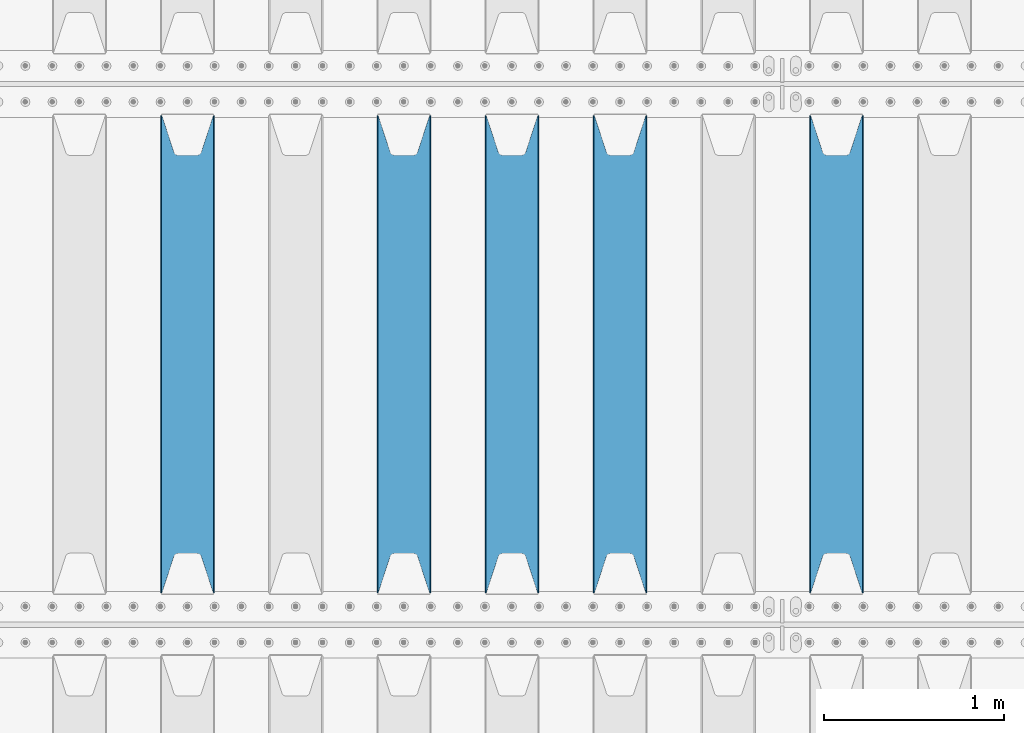
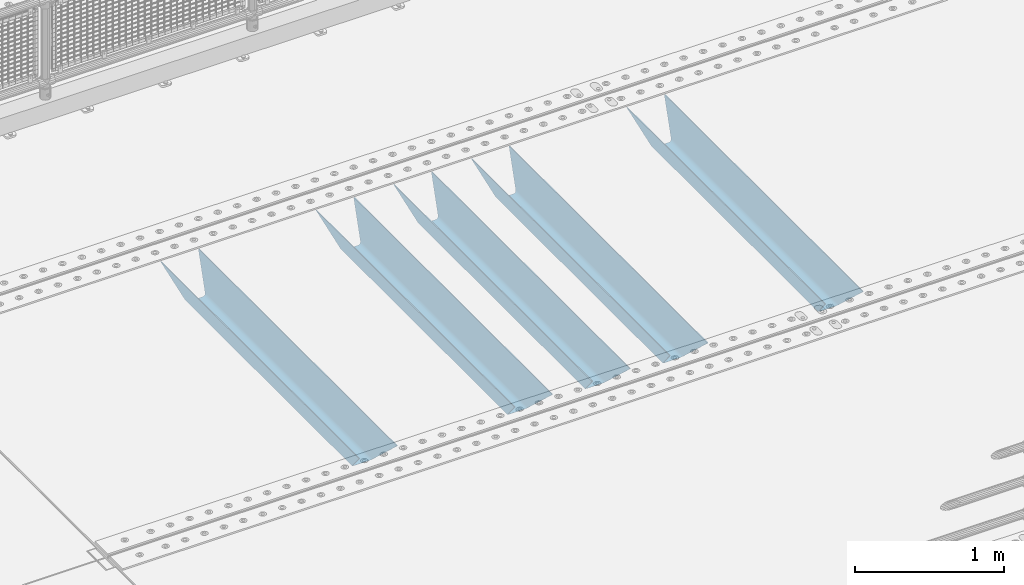
# One storey, part 111 of 247: 5 beams.
"""IFC2X3 building model written with IfcOpenShell, lengths in millimetres."""

from ifc_helpers import new_model, si_unit, frame, origin_with_axes, place, context, subcontext, project, spatial, faceted_brep, material, type_object, element, save


model = new_model("IFC2X3")

# Units and contexts
model_context = context("Model", 3, precision=1e-05, world=origin_with_axes())
body_context = subcontext(model_context, "Body", "Model", "MODEL_VIEW")
ifc_project = project(units=[si_unit("LENGTHUNIT", "METRE", prefix="MILLI"), si_unit("AREAUNIT", "SQUARE_METRE"), si_unit("VOLUMEUNIT", "CUBIC_METRE"), si_unit("MASSUNIT", "GRAM", prefix="KILO"), si_unit("TIMEUNIT", "SECOND"), si_unit("PLANEANGLEUNIT", "RADIAN"), si_unit("SOLIDANGLEUNIT", "STERADIAN"), si_unit("THERMODYNAMICTEMPERATUREUNIT", "DEGREE_CELSIUS"), si_unit("LUMINOUSINTENSITYUNIT", "LUMEN")], contexts=[model_context])

# Site, building, storey
site_placement = place(None, origin_with_axes())
site = spatial("IfcSite", under=ifc_project, at=site_placement, CompositionType="ELEMENT")
building_placement = place(site_placement, origin_with_axes())
building = spatial("IfcBuilding", under=site, at=building_placement, Name="Standard", CompositionType="ELEMENT")
storey_placement = place(building_placement, origin_with_axes())
storey = spatial("IfcBuildingStorey", under=building, at=storey_placement, Name="Undefined", CompositionType="ELEMENT", Elevation=0.0)

# Beams
ifc_material = material(Name="STEEL/S355N")
beam_type = type_object("IfcBeamType", PredefinedType="NOTDEFINED")
beam_1_placement = place(storey_placement, frame((5800.0, 3175.0, -115.0), z_axis=(0.0, 0.0, 1.0), x_axis=(0.0, 1.0, 0.0)))
element("IfcBeam", 1, at=beam_1_placement, inside=storey, type_object=beam_type, material=ifc_material, context=body_context, shape_type="Brep", body=[
    faceted_brep([(0.0, 150.0, 115.0), (0.0, 143.689999999999, 115.0), (2650.00000000297, 143.689999999999, 115.0), (2650.00000000297, 150.0, 115.0), (2650.00000000297, 142.059565218402, 110.0000000031), (2650.00000000297, 148.369565218403, 110.0000000031), (2441.90079219208, -80.1103600731112, -98.0992078077845), (2437.7588105432, -77.5672621345584, -102.241189456673), (2434.06523489746, -74.4080125315522, -105.934765102404), (2430.91086095089, -70.710272125576, -109.089139048974), (2428.37322971128, -66.5649389910068, -111.626770288588), (2426.51472138054, -62.0739139532889, -113.485278619323), (2425.38102192091, -57.3475956567672, -114.618978078955), (2424.99999999987, -52.5021667386536, -115.0), (2424.99999999987, 52.5021667386536, -115.0), (2425.38102192091, 57.3475956567672, -114.618978078955), (2426.51472138054, 62.0739139532889, -113.485278619323), (2428.37322971128, 66.5649389910068, -111.626770288588), (2430.91086095089, 70.710272125576, -109.089139048974), (2434.06523489746, 74.4080125315522, -105.934765102404), (2437.7588105432, 77.5672621345584, -102.241189456673), (2441.90079219208, 80.1103600731112, -98.0992078077846), (2446.38936140511, 81.9747917625791, -93.6106385947584), (2448.24948500409, 76.2713538057251, -91.7505149957729), (2444.62967112262, 74.76777986261, -95.3703288772456), (2441.28936334126, 72.7168944282894, -98.710636658607), (2438.31067330438, 70.1691124903846, -101.689326695487), (2435.76682334747, 67.1870637758839, -104.233176652398), (2433.72034654133, 63.8440531834895, -106.279653458539), (2432.22154950041, 60.222258798236, -107.778450499454), (2431.30727574265, 56.4107117849089, -108.692724257221), (2430.99999999987, 52.5031078186876, -109.0), (2430.99999999987, -52.5031078186876, -109.0), (2431.30727574265, -56.4107117849089, -108.692724257221), (2432.22154950041, -60.222258798236, -107.778450499454), (2433.72034654133, -63.8440531834895, -106.279653458539), (2435.76682334747, -67.1870637758839, -104.233176652398), (2438.31067330438, -70.1691124903846, -101.689326695487), (2441.28936334126, -72.7168944282894, -98.7106366586071), (2444.62967112262, -74.76777986261, -95.3703288772457), (2448.24948500409, -76.2713538057251, -91.7505149957729), (2650.00000000297, -142.059565218402, 110.0000000031), (2650.00000000297, -148.369565218403, 110.0000000031), (2446.38936140511, -81.9747917625791, -93.6106385947584), (2650.00000000297, -143.689999999999, 115.0), (2650.00000000297, -150.0, 115.0), (0.0, -143.689999999999, 115.0), (0.0, -150.0, 115.0), (0.0, -148.369565218261, 110.000000002663), (203.610638597422, -81.9747917625791, -93.6106385947584), (208.099207810448, -80.1103600731112, -98.0992078077845), (212.241189459336, -77.5672621345584, -102.241189456673), (215.934765105068, -74.4080125315522, -105.934765102404), (219.089139051637, -70.710272125576, -109.089139048974), (221.626770291251, -66.5649389910068, -111.626770288588), (223.485278621985, -62.0739139532889, -113.485278619323), (224.618978081617, -57.3475956567672, -114.618978078955), (225.000000002663, -52.5021667386536, -115.0), (225.000000002663, 52.5021667386536, -115.0), (224.618978081617, 57.3475956567672, -114.618978078955), (223.485278621985, 62.0739139532889, -113.485278619323), (221.626770291251, 66.5649389910068, -111.626770288588), (219.089139051637, 70.710272125576, -109.089139048974), (215.934765105068, 74.4080125315522, -105.934765102404), (212.241189459336, 77.5672621345584, -102.241189456673), (208.099207810448, 80.1103600731112, -98.0992078077846), (203.610638597422, 81.9747917625791, -93.6106385947584), (0.0, 148.369565218261, 110.000000002663), (0.0, 142.05956521826, 110.000000002663), (201.750514998436, 76.2713538057251, -91.7505149957729), (205.370328879908, 74.76777986261, -95.3703288772456), (208.710636661271, 72.7168944282894, -98.710636658607), (211.68932669815, 70.1691124903846, -101.689326695487), (214.233176655061, 67.1870637758839, -104.233176652398), (216.279653461202, 63.8440531834895, -106.279653458539), (217.778450502117, 60.222258798236, -107.778450499454), (218.692724259885, 56.4107117849089, -108.692724257221), (219.000000002663, 52.5031078186876, -109.0), (219.000000002663, -52.5031078186876, -109.0), (218.692724259885, -56.4107117849089, -108.692724257221), (217.778450502117, -60.222258798236, -107.778450499454), (216.279653461202, -63.8440531834895, -106.279653458539), (214.233176655061, -67.1870637758839, -104.233176652398), (211.68932669815, -70.1691124903846, -101.689326695487), (208.710636661271, -72.7168944282894, -98.7106366586071), (205.370328879908, -74.76777986261, -95.3703288772457), (201.750514998436, -76.2713538057251, -91.7505149957729), (0.0, -142.05956521826, 110.000000002663)], [[[0, 1, 2, 3]], [[3, 2, 4, 5]], [[6, 7, 8, 9, 10, 11, 12, 13, 14, 15, 16, 17, 18, 19, 20, 21, 22, 5, 4, 23, 24, 25, 26, 27, 28, 29, 30, 31, 32, 33, 34, 35, 36, 37, 38, 39, 40, 41, 42, 43]], [[44, 45, 42, 41]], [[46, 47, 45, 44]], [[43, 42, 45, 47, 48, 49]], [[6, 43, 49, 50]], [[7, 6, 50, 51]], [[8, 7, 51, 52]], [[9, 8, 52, 53]], [[10, 9, 53, 54]], [[11, 10, 54, 55]], [[12, 11, 55, 56]], [[13, 12, 56, 57]], [[14, 13, 57, 58]], [[15, 14, 58, 59]], [[16, 15, 59, 60]], [[17, 16, 60, 61]], [[18, 17, 61, 62]], [[19, 18, 62, 63]], [[20, 19, 63, 64]], [[21, 20, 64, 65]], [[22, 21, 65, 66]], [[0, 3, 5, 22, 66, 67]], [[1, 0, 67, 68]], [[23, 4, 2, 1, 68, 69]], [[24, 23, 69, 70]], [[25, 24, 70, 71]], [[26, 25, 71, 72]], [[27, 26, 72, 73]], [[28, 27, 73, 74]], [[29, 28, 74, 75]], [[30, 29, 75, 76]], [[31, 30, 76, 77]], [[32, 31, 77, 78]], [[33, 32, 78, 79]], [[34, 33, 79, 80]], [[35, 34, 80, 81]], [[36, 35, 81, 82]], [[37, 36, 82, 83]], [[38, 37, 83, 84]], [[39, 38, 84, 85]], [[40, 39, 85, 86]], [[46, 44, 41, 40, 86, 87]], [[47, 46, 87, 48]], [[86, 85, 84, 83, 82, 81, 80, 79, 78, 77, 76, 75, 74, 73, 72, 71, 70, 69, 68, 67, 66, 65, 64, 63, 62, 61, 60, 59, 58, 57, 56, 55, 54, 53, 52, 51, 50, 49, 48, 87]]]),
])
beam_2_placement = place(storey_placement, frame((4600.0, 3175.0, -115.0), z_axis=(0.0, 0.0, 1.0), x_axis=(0.0, 1.0, 0.0)))
element("IfcBeam", 2, at=beam_2_placement, inside=storey, type_object=beam_type, material=ifc_material, context=body_context, shape_type="Brep", body=[
    faceted_brep([(0.0, 150.0, 115.0), (0.0, 143.689999999999, 115.0), (2650.00000000297, 143.689999999999, 115.0), (2650.00000000297, 150.0, 115.0), (2650.00000000297, 142.059565218402, 110.0000000031), (2650.00000000297, 148.369565218403, 110.0000000031), (2441.90079219208, -80.1103600731112, -98.0992078077845), (2437.7588105432, -77.5672621345584, -102.241189456673), (2434.06523489746, -74.4080125315522, -105.934765102404), (2430.91086095089, -70.710272125576, -109.089139048974), (2428.37322971128, -66.5649389910068, -111.626770288588), (2426.51472138054, -62.0739139532889, -113.485278619323), (2425.38102192091, -57.3475956567672, -114.618978078955), (2424.99999999987, -52.5021667386536, -115.0), (2424.99999999987, 52.5021667386536, -115.0), (2425.38102192091, 57.3475956567672, -114.618978078955), (2426.51472138054, 62.0739139532889, -113.485278619323), (2428.37322971128, 66.5649389910068, -111.626770288588), (2430.91086095089, 70.710272125576, -109.089139048974), (2434.06523489746, 74.4080125315522, -105.934765102404), (2437.7588105432, 77.5672621345584, -102.241189456673), (2441.90079219208, 80.1103600731112, -98.0992078077846), (2446.38936140511, 81.9747917625791, -93.6106385947584), (2448.24948500409, 76.2713538057251, -91.7505149957729), (2444.62967112262, 74.76777986261, -95.3703288772456), (2441.28936334126, 72.7168944282894, -98.710636658607), (2438.31067330438, 70.1691124903846, -101.689326695487), (2435.76682334747, 67.1870637758839, -104.233176652398), (2433.72034654133, 63.8440531834895, -106.279653458539), (2432.22154950041, 60.222258798236, -107.778450499454), (2431.30727574265, 56.4107117849089, -108.692724257221), (2430.99999999987, 52.5031078186876, -109.0), (2430.99999999987, -52.5031078186876, -109.0), (2431.30727574265, -56.4107117849089, -108.692724257221), (2432.22154950041, -60.222258798236, -107.778450499454), (2433.72034654133, -63.8440531834895, -106.279653458539), (2435.76682334747, -67.1870637758839, -104.233176652398), (2438.31067330438, -70.1691124903846, -101.689326695487), (2441.28936334126, -72.7168944282894, -98.7106366586071), (2444.62967112262, -74.76777986261, -95.3703288772457), (2448.24948500409, -76.2713538057251, -91.7505149957729), (2650.00000000297, -142.059565218402, 110.0000000031), (2650.00000000297, -148.369565218403, 110.0000000031), (2446.38936140511, -81.9747917625791, -93.6106385947584), (2650.00000000297, -143.689999999999, 115.0), (2650.00000000297, -150.0, 115.0), (0.0, -143.689999999999, 115.0), (0.0, -150.0, 115.0), (0.0, -148.369565218261, 110.000000002663), (203.610638597422, -81.9747917625791, -93.6106385947584), (208.099207810448, -80.1103600731112, -98.0992078077845), (212.241189459336, -77.5672621345584, -102.241189456673), (215.934765105068, -74.4080125315522, -105.934765102404), (219.089139051637, -70.710272125576, -109.089139048974), (221.626770291251, -66.5649389910068, -111.626770288588), (223.485278621985, -62.0739139532889, -113.485278619323), (224.618978081617, -57.3475956567672, -114.618978078955), (225.000000002663, -52.5021667386536, -115.0), (225.000000002663, 52.5021667386536, -115.0), (224.618978081617, 57.3475956567672, -114.618978078955), (223.485278621985, 62.0739139532889, -113.485278619323), (221.626770291251, 66.5649389910068, -111.626770288588), (219.089139051637, 70.710272125576, -109.089139048974), (215.934765105068, 74.4080125315522, -105.934765102404), (212.241189459336, 77.5672621345584, -102.241189456673), (208.099207810448, 80.1103600731112, -98.0992078077846), (203.610638597422, 81.9747917625791, -93.6106385947584), (0.0, 148.369565218261, 110.000000002663), (0.0, 142.05956521826, 110.000000002663), (201.750514998436, 76.2713538057251, -91.7505149957729), (205.370328879908, 74.76777986261, -95.3703288772456), (208.710636661271, 72.7168944282894, -98.710636658607), (211.68932669815, 70.1691124903846, -101.689326695487), (214.233176655061, 67.1870637758839, -104.233176652398), (216.279653461202, 63.8440531834895, -106.279653458539), (217.778450502117, 60.222258798236, -107.778450499454), (218.692724259885, 56.4107117849089, -108.692724257221), (219.000000002663, 52.5031078186876, -109.0), (219.000000002663, -52.5031078186876, -109.0), (218.692724259885, -56.4107117849089, -108.692724257221), (217.778450502117, -60.222258798236, -107.778450499454), (216.279653461202, -63.8440531834895, -106.279653458539), (214.233176655061, -67.1870637758839, -104.233176652398), (211.68932669815, -70.1691124903846, -101.689326695487), (208.710636661271, -72.7168944282894, -98.7106366586071), (205.370328879908, -74.76777986261, -95.3703288772457), (201.750514998436, -76.2713538057251, -91.7505149957729), (0.0, -142.05956521826, 110.000000002663)], [[[0, 1, 2, 3]], [[3, 2, 4, 5]], [[6, 7, 8, 9, 10, 11, 12, 13, 14, 15, 16, 17, 18, 19, 20, 21, 22, 5, 4, 23, 24, 25, 26, 27, 28, 29, 30, 31, 32, 33, 34, 35, 36, 37, 38, 39, 40, 41, 42, 43]], [[44, 45, 42, 41]], [[46, 47, 45, 44]], [[43, 42, 45, 47, 48, 49]], [[6, 43, 49, 50]], [[7, 6, 50, 51]], [[8, 7, 51, 52]], [[9, 8, 52, 53]], [[10, 9, 53, 54]], [[11, 10, 54, 55]], [[12, 11, 55, 56]], [[13, 12, 56, 57]], [[14, 13, 57, 58]], [[15, 14, 58, 59]], [[16, 15, 59, 60]], [[17, 16, 60, 61]], [[18, 17, 61, 62]], [[19, 18, 62, 63]], [[20, 19, 63, 64]], [[21, 20, 64, 65]], [[22, 21, 65, 66]], [[0, 3, 5, 22, 66, 67]], [[1, 0, 67, 68]], [[23, 4, 2, 1, 68, 69]], [[24, 23, 69, 70]], [[25, 24, 70, 71]], [[26, 25, 71, 72]], [[27, 26, 72, 73]], [[28, 27, 73, 74]], [[29, 28, 74, 75]], [[30, 29, 75, 76]], [[31, 30, 76, 77]], [[32, 31, 77, 78]], [[33, 32, 78, 79]], [[34, 33, 79, 80]], [[35, 34, 80, 81]], [[36, 35, 81, 82]], [[37, 36, 82, 83]], [[38, 37, 83, 84]], [[39, 38, 84, 85]], [[40, 39, 85, 86]], [[46, 44, 41, 40, 86, 87]], [[47, 46, 87, 48]], [[86, 85, 84, 83, 82, 81, 80, 79, 78, 77, 76, 75, 74, 73, 72, 71, 70, 69, 68, 67, 66, 65, 64, 63, 62, 61, 60, 59, 58, 57, 56, 55, 54, 53, 52, 51, 50, 49, 48, 87]]]),
])
beam_3_placement = place(storey_placement, frame((4000.0, 3175.0, -115.0), z_axis=(0.0, 0.0, 1.0), x_axis=(0.0, 1.0, 0.0)))
element("IfcBeam", 3, at=beam_3_placement, inside=storey, type_object=beam_type, material=ifc_material, context=body_context, shape_type="Brep", body=[
    faceted_brep([(0.0, 150.0, 115.0), (0.0, 143.689999999999, 115.0), (2650.00000000297, 143.689999999999, 115.0), (2650.00000000297, 150.0, 115.0), (2650.00000000297, 142.059565218402, 110.0000000031), (2650.00000000297, 148.369565218403, 110.0000000031), (2441.90079219208, -80.1103600731112, -98.0992078077845), (2437.7588105432, -77.5672621345584, -102.241189456673), (2434.06523489746, -74.4080125315522, -105.934765102404), (2430.91086095089, -70.710272125576, -109.089139048974), (2428.37322971128, -66.5649389910068, -111.626770288588), (2426.51472138054, -62.0739139532889, -113.485278619323), (2425.38102192091, -57.3475956567672, -114.618978078955), (2424.99999999987, -52.5021667386536, -115.0), (2424.99999999987, 52.5021667386536, -115.0), (2425.38102192091, 57.3475956567672, -114.618978078955), (2426.51472138054, 62.0739139532889, -113.485278619323), (2428.37322971128, 66.5649389910068, -111.626770288588), (2430.91086095089, 70.710272125576, -109.089139048974), (2434.06523489746, 74.4080125315522, -105.934765102404), (2437.7588105432, 77.5672621345584, -102.241189456673), (2441.90079219208, 80.1103600731112, -98.0992078077846), (2446.38936140511, 81.9747917625791, -93.6106385947584), (2448.24948500409, 76.2713538057251, -91.7505149957729), (2444.62967112262, 74.76777986261, -95.3703288772456), (2441.28936334126, 72.7168944282894, -98.710636658607), (2438.31067330438, 70.1691124903846, -101.689326695487), (2435.76682334747, 67.1870637758839, -104.233176652398), (2433.72034654133, 63.8440531834895, -106.279653458539), (2432.22154950041, 60.222258798236, -107.778450499454), (2431.30727574265, 56.4107117849089, -108.692724257221), (2430.99999999987, 52.5031078186876, -109.0), (2430.99999999987, -52.5031078186876, -109.0), (2431.30727574265, -56.4107117849089, -108.692724257221), (2432.22154950041, -60.222258798236, -107.778450499454), (2433.72034654133, -63.8440531834895, -106.279653458539), (2435.76682334747, -67.1870637758839, -104.233176652398), (2438.31067330438, -70.1691124903846, -101.689326695487), (2441.28936334126, -72.7168944282894, -98.7106366586071), (2444.62967112262, -74.76777986261, -95.3703288772457), (2448.24948500409, -76.2713538057251, -91.7505149957729), (2650.00000000297, -142.059565218402, 110.0000000031), (2650.00000000297, -148.369565218403, 110.0000000031), (2446.38936140511, -81.9747917625791, -93.6106385947584), (2650.00000000297, -143.689999999999, 115.0), (2650.00000000297, -150.0, 115.0), (0.0, -143.689999999999, 115.0), (0.0, -150.0, 115.0), (0.0, -148.369565218261, 110.000000002663), (203.610638597422, -81.9747917625791, -93.6106385947584), (208.099207810448, -80.1103600731112, -98.0992078077845), (212.241189459336, -77.5672621345584, -102.241189456673), (215.934765105068, -74.4080125315522, -105.934765102404), (219.089139051637, -70.710272125576, -109.089139048974), (221.626770291251, -66.5649389910068, -111.626770288588), (223.485278621985, -62.0739139532889, -113.485278619323), (224.618978081617, -57.3475956567672, -114.618978078955), (225.000000002663, -52.5021667386536, -115.0), (225.000000002663, 52.5021667386536, -115.0), (224.618978081617, 57.3475956567672, -114.618978078955), (223.485278621985, 62.0739139532889, -113.485278619323), (221.626770291251, 66.5649389910068, -111.626770288588), (219.089139051637, 70.710272125576, -109.089139048974), (215.934765105068, 74.4080125315522, -105.934765102404), (212.241189459336, 77.5672621345584, -102.241189456673), (208.099207810448, 80.1103600731112, -98.0992078077846), (203.610638597422, 81.9747917625791, -93.6106385947584), (0.0, 148.369565218261, 110.000000002663), (0.0, 142.05956521826, 110.000000002663), (201.750514998436, 76.2713538057251, -91.7505149957729), (205.370328879908, 74.76777986261, -95.3703288772456), (208.710636661271, 72.7168944282894, -98.710636658607), (211.68932669815, 70.1691124903846, -101.689326695487), (214.233176655061, 67.1870637758839, -104.233176652398), (216.279653461202, 63.8440531834895, -106.279653458539), (217.778450502117, 60.222258798236, -107.778450499454), (218.692724259885, 56.4107117849089, -108.692724257221), (219.000000002663, 52.5031078186876, -109.0), (219.000000002663, -52.5031078186876, -109.0), (218.692724259885, -56.4107117849089, -108.692724257221), (217.778450502117, -60.222258798236, -107.778450499454), (216.279653461202, -63.8440531834895, -106.279653458539), (214.233176655061, -67.1870637758839, -104.233176652398), (211.68932669815, -70.1691124903846, -101.689326695487), (208.710636661271, -72.7168944282894, -98.7106366586071), (205.370328879908, -74.76777986261, -95.3703288772457), (201.750514998436, -76.2713538057251, -91.7505149957729), (0.0, -142.05956521826, 110.000000002663)], [[[0, 1, 2, 3]], [[3, 2, 4, 5]], [[6, 7, 8, 9, 10, 11, 12, 13, 14, 15, 16, 17, 18, 19, 20, 21, 22, 5, 4, 23, 24, 25, 26, 27, 28, 29, 30, 31, 32, 33, 34, 35, 36, 37, 38, 39, 40, 41, 42, 43]], [[44, 45, 42, 41]], [[46, 47, 45, 44]], [[43, 42, 45, 47, 48, 49]], [[6, 43, 49, 50]], [[7, 6, 50, 51]], [[8, 7, 51, 52]], [[9, 8, 52, 53]], [[10, 9, 53, 54]], [[11, 10, 54, 55]], [[12, 11, 55, 56]], [[13, 12, 56, 57]], [[14, 13, 57, 58]], [[15, 14, 58, 59]], [[16, 15, 59, 60]], [[17, 16, 60, 61]], [[18, 17, 61, 62]], [[19, 18, 62, 63]], [[20, 19, 63, 64]], [[21, 20, 64, 65]], [[22, 21, 65, 66]], [[0, 3, 5, 22, 66, 67]], [[1, 0, 67, 68]], [[23, 4, 2, 1, 68, 69]], [[24, 23, 69, 70]], [[25, 24, 70, 71]], [[26, 25, 71, 72]], [[27, 26, 72, 73]], [[28, 27, 73, 74]], [[29, 28, 74, 75]], [[30, 29, 75, 76]], [[31, 30, 76, 77]], [[32, 31, 77, 78]], [[33, 32, 78, 79]], [[34, 33, 79, 80]], [[35, 34, 80, 81]], [[36, 35, 81, 82]], [[37, 36, 82, 83]], [[38, 37, 83, 84]], [[39, 38, 84, 85]], [[40, 39, 85, 86]], [[46, 44, 41, 40, 86, 87]], [[47, 46, 87, 48]], [[86, 85, 84, 83, 82, 81, 80, 79, 78, 77, 76, 75, 74, 73, 72, 71, 70, 69, 68, 67, 66, 65, 64, 63, 62, 61, 60, 59, 58, 57, 56, 55, 54, 53, 52, 51, 50, 49, 48, 87]]]),
])
beam_4_placement = place(storey_placement, frame((3400.0, 3175.0, -115.0), z_axis=(0.0, 0.0, 1.0), x_axis=(0.0, 1.0, 0.0)))
element("IfcBeam", 4, at=beam_4_placement, inside=storey, type_object=beam_type, material=ifc_material, context=body_context, shape_type="Brep", body=[
    faceted_brep([(0.0, 150.0, 115.0), (0.0, 143.689999999999, 115.0), (2650.00000000297, 143.689999999999, 115.0), (2650.00000000297, 150.0, 115.0), (2650.00000000297, 142.059565218402, 110.0000000031), (2650.00000000297, 148.369565218403, 110.0000000031), (2441.90079219208, -80.1103600731112, -98.0992078077845), (2437.7588105432, -77.5672621345584, -102.241189456673), (2434.06523489746, -74.4080125315522, -105.934765102404), (2430.91086095089, -70.710272125576, -109.089139048974), (2428.37322971128, -66.5649389910068, -111.626770288588), (2426.51472138054, -62.0739139532889, -113.485278619323), (2425.38102192091, -57.3475956567672, -114.618978078955), (2424.99999999987, -52.5021667386536, -115.0), (2424.99999999987, 52.5021667386536, -115.0), (2425.38102192091, 57.3475956567672, -114.618978078955), (2426.51472138054, 62.0739139532889, -113.485278619323), (2428.37322971128, 66.5649389910068, -111.626770288588), (2430.91086095089, 70.710272125576, -109.089139048974), (2434.06523489746, 74.4080125315522, -105.934765102404), (2437.7588105432, 77.5672621345584, -102.241189456673), (2441.90079219208, 80.1103600731112, -98.0992078077846), (2446.38936140511, 81.9747917625791, -93.6106385947584), (2448.24948500409, 76.2713538057251, -91.7505149957729), (2444.62967112262, 74.76777986261, -95.3703288772456), (2441.28936334126, 72.7168944282894, -98.710636658607), (2438.31067330438, 70.1691124903846, -101.689326695487), (2435.76682334747, 67.1870637758839, -104.233176652398), (2433.72034654133, 63.8440531834895, -106.279653458539), (2432.22154950041, 60.222258798236, -107.778450499454), (2431.30727574265, 56.4107117849089, -108.692724257221), (2430.99999999987, 52.5031078186876, -109.0), (2430.99999999987, -52.5031078186876, -109.0), (2431.30727574265, -56.4107117849089, -108.692724257221), (2432.22154950041, -60.222258798236, -107.778450499454), (2433.72034654133, -63.8440531834895, -106.279653458539), (2435.76682334747, -67.1870637758839, -104.233176652398), (2438.31067330438, -70.1691124903846, -101.689326695487), (2441.28936334126, -72.7168944282894, -98.7106366586071), (2444.62967112262, -74.76777986261, -95.3703288772457), (2448.24948500409, -76.2713538057251, -91.7505149957729), (2650.00000000297, -142.059565218402, 110.0000000031), (2650.00000000297, -148.369565218403, 110.0000000031), (2446.38936140511, -81.9747917625791, -93.6106385947584), (2650.00000000297, -143.689999999999, 115.0), (2650.00000000297, -150.0, 115.0), (0.0, -143.689999999999, 115.0), (0.0, -150.0, 115.0), (0.0, -148.369565218261, 110.000000002663), (203.610638597422, -81.9747917625791, -93.6106385947584), (208.099207810448, -80.1103600731112, -98.0992078077845), (212.241189459336, -77.5672621345584, -102.241189456673), (215.934765105068, -74.4080125315522, -105.934765102404), (219.089139051637, -70.710272125576, -109.089139048974), (221.626770291251, -66.5649389910068, -111.626770288588), (223.485278621985, -62.0739139532889, -113.485278619323), (224.618978081617, -57.3475956567672, -114.618978078955), (225.000000002663, -52.5021667386536, -115.0), (225.000000002663, 52.5021667386536, -115.0), (224.618978081617, 57.3475956567672, -114.618978078955), (223.485278621985, 62.0739139532889, -113.485278619323), (221.626770291251, 66.5649389910068, -111.626770288588), (219.089139051637, 70.710272125576, -109.089139048974), (215.934765105068, 74.4080125315522, -105.934765102404), (212.241189459336, 77.5672621345584, -102.241189456673), (208.099207810448, 80.1103600731112, -98.0992078077846), (203.610638597422, 81.9747917625791, -93.6106385947584), (0.0, 148.369565218261, 110.000000002663), (0.0, 142.05956521826, 110.000000002663), (201.750514998436, 76.2713538057251, -91.7505149957729), (205.370328879908, 74.76777986261, -95.3703288772456), (208.710636661271, 72.7168944282894, -98.710636658607), (211.68932669815, 70.1691124903846, -101.689326695487), (214.233176655061, 67.1870637758839, -104.233176652398), (216.279653461202, 63.8440531834895, -106.279653458539), (217.778450502117, 60.222258798236, -107.778450499454), (218.692724259885, 56.4107117849089, -108.692724257221), (219.000000002663, 52.5031078186876, -109.0), (219.000000002663, -52.5031078186876, -109.0), (218.692724259885, -56.4107117849089, -108.692724257221), (217.778450502117, -60.222258798236, -107.778450499454), (216.279653461202, -63.8440531834895, -106.279653458539), (214.233176655061, -67.1870637758839, -104.233176652398), (211.68932669815, -70.1691124903846, -101.689326695487), (208.710636661271, -72.7168944282894, -98.7106366586071), (205.370328879908, -74.76777986261, -95.3703288772457), (201.750514998436, -76.2713538057251, -91.7505149957729), (0.0, -142.05956521826, 110.000000002663)], [[[0, 1, 2, 3]], [[3, 2, 4, 5]], [[6, 7, 8, 9, 10, 11, 12, 13, 14, 15, 16, 17, 18, 19, 20, 21, 22, 5, 4, 23, 24, 25, 26, 27, 28, 29, 30, 31, 32, 33, 34, 35, 36, 37, 38, 39, 40, 41, 42, 43]], [[44, 45, 42, 41]], [[46, 47, 45, 44]], [[43, 42, 45, 47, 48, 49]], [[6, 43, 49, 50]], [[7, 6, 50, 51]], [[8, 7, 51, 52]], [[9, 8, 52, 53]], [[10, 9, 53, 54]], [[11, 10, 54, 55]], [[12, 11, 55, 56]], [[13, 12, 56, 57]], [[14, 13, 57, 58]], [[15, 14, 58, 59]], [[16, 15, 59, 60]], [[17, 16, 60, 61]], [[18, 17, 61, 62]], [[19, 18, 62, 63]], [[20, 19, 63, 64]], [[21, 20, 64, 65]], [[22, 21, 65, 66]], [[0, 3, 5, 22, 66, 67]], [[1, 0, 67, 68]], [[23, 4, 2, 1, 68, 69]], [[24, 23, 69, 70]], [[25, 24, 70, 71]], [[26, 25, 71, 72]], [[27, 26, 72, 73]], [[28, 27, 73, 74]], [[29, 28, 74, 75]], [[30, 29, 75, 76]], [[31, 30, 76, 77]], [[32, 31, 77, 78]], [[33, 32, 78, 79]], [[34, 33, 79, 80]], [[35, 34, 80, 81]], [[36, 35, 81, 82]], [[37, 36, 82, 83]], [[38, 37, 83, 84]], [[39, 38, 84, 85]], [[40, 39, 85, 86]], [[46, 44, 41, 40, 86, 87]], [[47, 46, 87, 48]], [[86, 85, 84, 83, 82, 81, 80, 79, 78, 77, 76, 75, 74, 73, 72, 71, 70, 69, 68, 67, 66, 65, 64, 63, 62, 61, 60, 59, 58, 57, 56, 55, 54, 53, 52, 51, 50, 49, 48, 87]]]),
])
beam_5_placement = place(storey_placement, frame((2200.0, 3175.0, -115.0), z_axis=(0.0, 0.0, 1.0), x_axis=(0.0, 1.0, 0.0)))
element("IfcBeam", 5, at=beam_5_placement, inside=storey, type_object=beam_type, material=ifc_material, context=body_context, shape_type="Brep", body=[
    faceted_brep([(0.0, 150.0, 115.0), (0.0, 143.689999999999, 115.0), (2650.00000000297, 143.689999999999, 115.0), (2650.00000000297, 150.0, 115.0), (2650.00000000297, 142.059565218402, 110.0000000031), (2650.00000000297, 148.369565218403, 110.0000000031), (2441.90079219208, -80.1103600731112, -98.0992078077845), (2437.7588105432, -77.5672621345584, -102.241189456673), (2434.06523489746, -74.4080125315522, -105.934765102404), (2430.91086095089, -70.710272125576, -109.089139048974), (2428.37322971128, -66.5649389910068, -111.626770288588), (2426.51472138054, -62.0739139532889, -113.485278619323), (2425.38102192091, -57.3475956567672, -114.618978078955), (2424.99999999987, -52.5021667386536, -115.0), (2424.99999999987, 52.5021667386536, -115.0), (2425.38102192091, 57.3475956567672, -114.618978078955), (2426.51472138054, 62.0739139532889, -113.485278619323), (2428.37322971128, 66.5649389910068, -111.626770288588), (2430.91086095089, 70.710272125576, -109.089139048974), (2434.06523489746, 74.4080125315522, -105.934765102404), (2437.7588105432, 77.5672621345584, -102.241189456673), (2441.90079219208, 80.1103600731112, -98.0992078077846), (2446.38936140511, 81.9747917625791, -93.6106385947584), (2448.24948500409, 76.2713538057251, -91.7505149957729), (2444.62967112262, 74.76777986261, -95.3703288772456), (2441.28936334126, 72.7168944282894, -98.710636658607), (2438.31067330438, 70.1691124903846, -101.689326695487), (2435.76682334747, 67.1870637758839, -104.233176652398), (2433.72034654133, 63.8440531834895, -106.279653458539), (2432.22154950041, 60.222258798236, -107.778450499454), (2431.30727574265, 56.4107117849089, -108.692724257221), (2430.99999999987, 52.5031078186876, -109.0), (2430.99999999987, -52.5031078186876, -109.0), (2431.30727574265, -56.4107117849089, -108.692724257221), (2432.22154950041, -60.222258798236, -107.778450499454), (2433.72034654133, -63.8440531834895, -106.279653458539), (2435.76682334747, -67.1870637758839, -104.233176652398), (2438.31067330438, -70.1691124903846, -101.689326695487), (2441.28936334126, -72.7168944282894, -98.7106366586071), (2444.62967112262, -74.76777986261, -95.3703288772457), (2448.24948500409, -76.2713538057251, -91.7505149957729), (2650.00000000297, -142.059565218402, 110.0000000031), (2650.00000000297, -148.369565218403, 110.0000000031), (2446.38936140511, -81.9747917625791, -93.6106385947584), (2650.00000000297, -143.689999999999, 115.0), (2650.00000000297, -150.0, 115.0), (0.0, -143.689999999999, 115.0), (0.0, -150.0, 115.0), (0.0, -148.369565218261, 110.000000002663), (203.610638597422, -81.9747917625791, -93.6106385947584), (208.099207810448, -80.1103600731112, -98.0992078077845), (212.241189459336, -77.5672621345584, -102.241189456673), (215.934765105068, -74.4080125315522, -105.934765102404), (219.089139051637, -70.710272125576, -109.089139048974), (221.626770291251, -66.5649389910068, -111.626770288588), (223.485278621985, -62.0739139532889, -113.485278619323), (224.618978081617, -57.3475956567672, -114.618978078955), (225.000000002663, -52.5021667386536, -115.0), (225.000000002663, 52.5021667386536, -115.0), (224.618978081617, 57.3475956567672, -114.618978078955), (223.485278621985, 62.0739139532889, -113.485278619323), (221.626770291251, 66.5649389910068, -111.626770288588), (219.089139051637, 70.710272125576, -109.089139048974), (215.934765105068, 74.4080125315522, -105.934765102404), (212.241189459336, 77.5672621345584, -102.241189456673), (208.099207810448, 80.1103600731112, -98.0992078077846), (203.610638597422, 81.9747917625791, -93.6106385947584), (0.0, 148.369565218261, 110.000000002663), (0.0, 142.05956521826, 110.000000002663), (201.750514998436, 76.2713538057251, -91.7505149957729), (205.370328879908, 74.76777986261, -95.3703288772456), (208.710636661271, 72.7168944282894, -98.710636658607), (211.68932669815, 70.1691124903846, -101.689326695487), (214.233176655061, 67.1870637758839, -104.233176652398), (216.279653461202, 63.8440531834895, -106.279653458539), (217.778450502117, 60.222258798236, -107.778450499454), (218.692724259885, 56.4107117849089, -108.692724257221), (219.000000002663, 52.5031078186876, -109.0), (219.000000002663, -52.5031078186876, -109.0), (218.692724259885, -56.4107117849089, -108.692724257221), (217.778450502117, -60.222258798236, -107.778450499454), (216.279653461202, -63.8440531834895, -106.279653458539), (214.233176655061, -67.1870637758839, -104.233176652398), (211.68932669815, -70.1691124903846, -101.689326695487), (208.710636661271, -72.7168944282894, -98.7106366586071), (205.370328879908, -74.76777986261, -95.3703288772457), (201.750514998436, -76.2713538057251, -91.7505149957729), (0.0, -142.05956521826, 110.000000002663)], [[[0, 1, 2, 3]], [[3, 2, 4, 5]], [[6, 7, 8, 9, 10, 11, 12, 13, 14, 15, 16, 17, 18, 19, 20, 21, 22, 5, 4, 23, 24, 25, 26, 27, 28, 29, 30, 31, 32, 33, 34, 35, 36, 37, 38, 39, 40, 41, 42, 43]], [[44, 45, 42, 41]], [[46, 47, 45, 44]], [[43, 42, 45, 47, 48, 49]], [[6, 43, 49, 50]], [[7, 6, 50, 51]], [[8, 7, 51, 52]], [[9, 8, 52, 53]], [[10, 9, 53, 54]], [[11, 10, 54, 55]], [[12, 11, 55, 56]], [[13, 12, 56, 57]], [[14, 13, 57, 58]], [[15, 14, 58, 59]], [[16, 15, 59, 60]], [[17, 16, 60, 61]], [[18, 17, 61, 62]], [[19, 18, 62, 63]], [[20, 19, 63, 64]], [[21, 20, 64, 65]], [[22, 21, 65, 66]], [[0, 3, 5, 22, 66, 67]], [[1, 0, 67, 68]], [[23, 4, 2, 1, 68, 69]], [[24, 23, 69, 70]], [[25, 24, 70, 71]], [[26, 25, 71, 72]], [[27, 26, 72, 73]], [[28, 27, 73, 74]], [[29, 28, 74, 75]], [[30, 29, 75, 76]], [[31, 30, 76, 77]], [[32, 31, 77, 78]], [[33, 32, 78, 79]], [[34, 33, 79, 80]], [[35, 34, 80, 81]], [[36, 35, 81, 82]], [[37, 36, 82, 83]], [[38, 37, 83, 84]], [[39, 38, 84, 85]], [[40, 39, 85, 86]], [[46, 44, 41, 40, 86, 87]], [[47, 46, 87, 48]], [[86, 85, 84, 83, 82, 81, 80, 79, 78, 77, 76, 75, 74, 73, 72, 71, 70, 69, 68, 67, 66, 65, 64, 63, 62, 61, 60, 59, 58, 57, 56, 55, 54, 53, 52, 51, 50, 49, 48, 87]]]),
])

save(model, "model.ifc")
